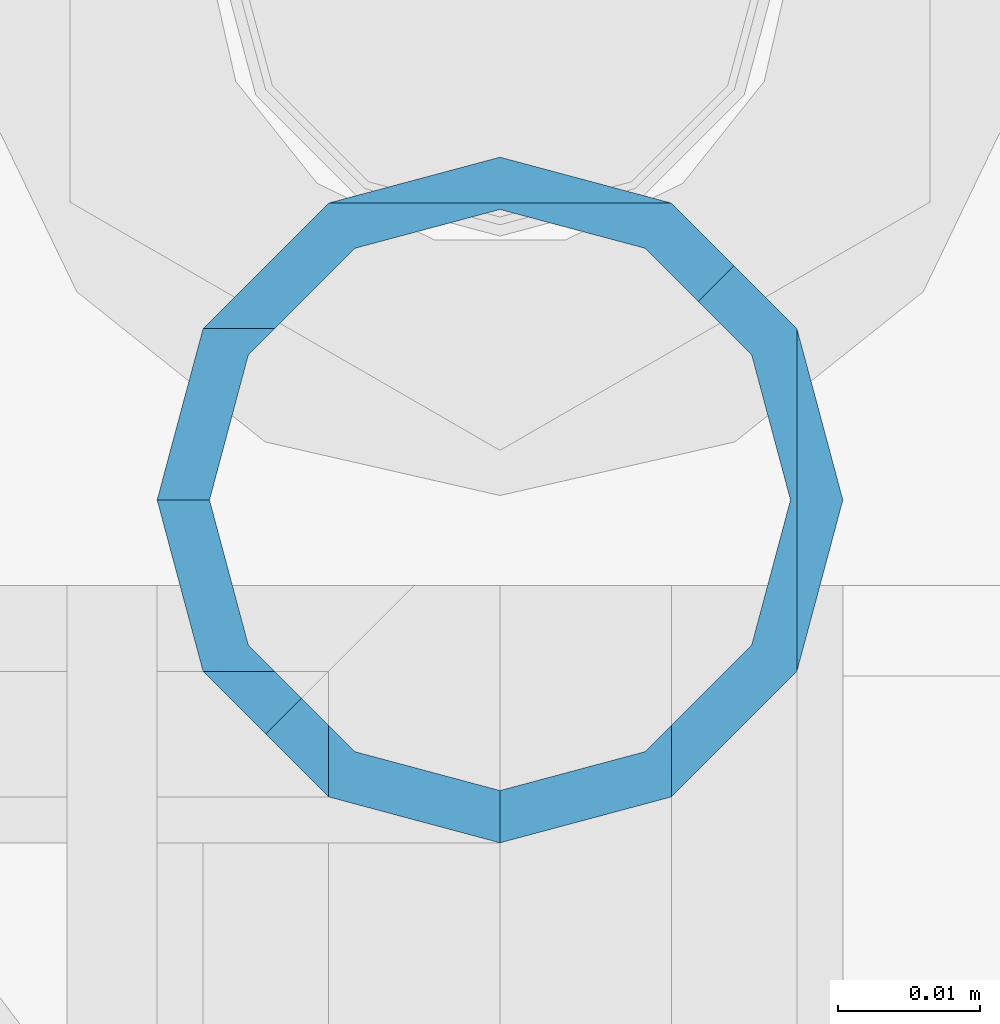
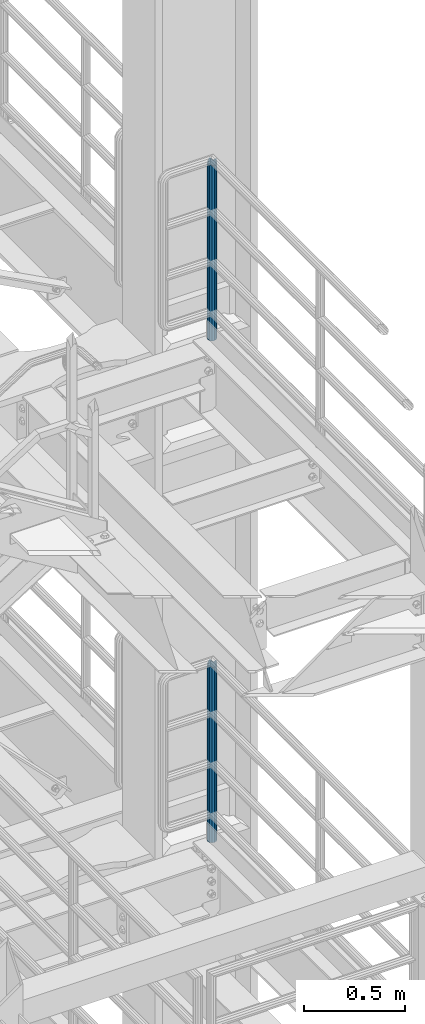
# One storey, part 665 of 1876: 2 columns, 2 elements without a shape of their own.
"""IFC2X3 building model written with IfcOpenShell, lengths in millimetres."""

from ifc_helpers import new_model, si_unit, frame, origin_with_axes, place, context, subcontext, project, spatial, faceted_brep, material, type_object, element, aggregate, save


model = new_model("IFC2X3")

# Units and contexts
model_context = context("Model", 3, precision=1e-05, world=origin_with_axes())
body_context = subcontext(model_context, "Body", "Model", "MODEL_VIEW")
ifc_project = project(units=[si_unit("LENGTHUNIT", "METRE", prefix="MILLI"), si_unit("AREAUNIT", "SQUARE_METRE"), si_unit("VOLUMEUNIT", "CUBIC_METRE"), si_unit("MASSUNIT", "GRAM", prefix="KILO"), si_unit("TIMEUNIT", "SECOND"), si_unit("PLANEANGLEUNIT", "RADIAN"), si_unit("SOLIDANGLEUNIT", "STERADIAN"), si_unit("THERMODYNAMICTEMPERATUREUNIT", "DEGREE_CELSIUS"), si_unit("LUMINOUSINTENSITYUNIT", "LUMEN")], contexts=[model_context])

# Site, building, storey
site_placement = place(None, origin_with_axes())
site = spatial("IfcSite", under=ifc_project, at=site_placement, CompositionType="ELEMENT")
building_placement = place(site_placement, origin_with_axes())
building = spatial("IfcBuilding", under=site, at=building_placement, Name="Undefined", CompositionType="ELEMENT")
storey_placement = place(building_placement, origin_with_axes())
storey = spatial("IfcBuildingStorey", under=building, at=storey_placement, Name="Undefined", CompositionType="ELEMENT", Elevation=0.0)

# Assembly, column
assembly_1_placement = place(storey_placement, origin_with_axes())
assembly_1 = element("IfcElementAssembly", 1, at=assembly_1_placement, inside=storey, Name="RAIL", AssemblyPlace="NOTDEFINED", PredefinedType="RIGID_FRAME")
ifc_material = material()
column_type = type_object("IfcColumnType", Name="PIPE1-1/2SCH40", PredefinedType="NOTDEFINED")
column_1_placement = place(assembly_1_placement, frame((7620.00000000001, -4788.2175, 8153.4), z_axis=(0.0, 1.0, 0.0), x_axis=(0.0, 0.0, 1.0)))
column_1 = element("IfcColumn", 2, at=column_1_placement, type_object=column_type, material=ifc_material, Name="POST", ObjectType="PIPE1-1/2SCH40", context=body_context, shape_type="Brep", body=[
    faceted_brep([(1076.325, 24.1300000000001, 0.0), (1064.26, 20.8971929933184, 12.0649999999996), (1064.25999999999, 20.8971929933186, -12.0649999999996), (1059.84389372958, 16.4810867391689, 16.4811062541503), (1057.32835795224, 13.9655509593422, 13.9655704718371), (1061.07042843786, 17.7076214311803, 10.2235000000001), (1063.80980700668, 20.4469999999999, 0.0), (1061.07042843786, 17.7076214311803, -10.2235000000001), (1055.42780700668, 12.0650000000001, -15.8661214311805), (1055.42780700667, 12.0649999999996, -20.8971929933186), (1054.93437856882, 10.2235000000001, -17.7076214311801), (1052.195, 0.0, -20.4470000000001), (1052.19499999999, 0.0, -24.1300000000001), (1055.42780700668, -12.0650000000001, -15.8661214311805), (1055.42780700667, -12.0649999999996, -20.8971929933186), (1054.93437856882, -10.2235000000001, -17.7076214311801), (1057.32837749231, -13.9655704718352, -13.9655509593449), (1059.84391327711, -16.4811062541476, -16.4810867391716), (1055.42780700668, -15.8661214311742, -12.065000000006), (1055.42780700668, -20.8971929933184, -12.0649999999996), (1054.93437856882, -17.7076214311801, -10.2235000000001), (1052.195, -20.4470000000001, 0.0), (1052.195, -24.1300000000001, 0.0), (1054.93437856882, -17.7076214311801, 10.2235000000001), (1055.42780700668, -15.8661214311869, 12.0649999999932), (1055.42780700668, -20.8971929933184, 12.0649999999996), (1076.325, 0.0, 24.1300000000001), (1064.26, -12.0650000000001, 20.8971929933186), (1064.26, 12.065, 20.8971929933186), (1061.07042843787, -10.2235000000001, 17.7076214311801), (1063.80980700669, 0.0, 20.4470000000001), (1061.07042843787, 10.2235000000001, 17.7076214311801), (0.0, -20.8971929933184, -12.0649999999996), (0.0, -12.0650000000001, -20.8971929933186), (-1.45519152283669e-11, 0.0, -24.130000000001), (0.0, 12.0650000000001, -20.8971929933186), (0.0, 20.8971929933184, -12.0649999999996), (0.0, 24.1299999999992, 0.0), (0.0, 20.8971929933184, 12.0649999999996), (0.0, 12.0650000000001, 20.8971929933186), (-1.45519152283669e-11, 0.0, 24.130000000001), (0.0, -20.8971929933184, 12.0649999999996), (0.0, -24.1299999999992, 0.0), (0.0, -12.0650000000001, 20.8971929933186), (0.0, -17.7076214311803, -10.2235000000001), (0.0, -10.2235000000001, -17.7076214311801), (-1.45519152283669e-11, 0.0, -20.4470000000001), (0.0, 10.2235000000001, -17.7076214311801), (0.0, 17.7076214311803, -10.2235000000001), (0.0, 20.4469999999999, 0.0), (0.0, 17.7076214311803, 10.2235000000001), (0.0, 10.2235000000001, 17.7076214311801), (-1.45519152283669e-11, 0.0, 20.4470000000001), (0.0, -10.2235000000001, 17.7076214311801), (0.0, -17.7076214311803, 10.2235000000001), (0.0, -20.4469999999999, 0.0)], [[[0, 1, 2]], [[3, 4, 5, 6, 7, 8, 9, 2, 1]], [[10, 11, 12, 9, 8]], [[13, 14, 12, 11, 15]], [[14, 13, 16, 17]], [[17, 16, 18, 19]], [[19, 18, 20, 21, 22]], [[22, 21, 23, 24, 25]], [[26, 27, 28]], [[25, 24, 29, 30, 31, 4, 3, 28, 27]], [[32, 33, 14, 17, 19]], [[33, 34, 12, 14]], [[34, 35, 9, 12]], [[35, 36, 2, 9]], [[36, 37, 0, 2]], [[37, 38, 1, 0]], [[1, 38, 39, 28, 3]], [[39, 40, 26, 28]], [[41, 42, 22, 25]], [[43, 41, 25, 27]], [[40, 43, 27, 26]], [[42, 32, 19, 22]], [[41, 43, 40, 39, 38, 37, 36, 35, 34, 33, 32, 42], [44, 45, 46, 47, 48, 49, 50, 51, 52, 53, 54, 55]], [[53, 52, 30, 29]], [[23, 54, 53, 29, 24]], [[55, 54, 23, 21]], [[44, 55, 21, 20]], [[15, 45, 44, 20, 18, 16, 13]], [[46, 45, 15, 11]], [[47, 46, 11, 10]], [[48, 47, 10, 8, 7]], [[49, 48, 7, 6]], [[50, 49, 6, 5]], [[51, 50, 5, 4, 31]], [[52, 51, 31, 30]]]),
])
aggregate(assembly_1, [column_1])

assembly_2_placement = place(storey_placement, origin_with_axes())
assembly_2 = element("IfcElementAssembly", 3, at=assembly_2_placement, inside=storey, Name="RAIL", AssemblyPlace="NOTDEFINED", PredefinedType="RIGID_FRAME")
column_2_placement = place(assembly_2_placement, frame((7620.00000000001, -4788.2175, 5130.8), z_axis=(0.0, 1.0, 0.0), x_axis=(0.0, 0.0, 1.0)))
column_2 = element("IfcColumn", 4, at=column_2_placement, type_object=column_type, material=ifc_material, Name="POST", ObjectType="PIPE1-1/2SCH40", context=body_context, shape_type="Brep", body=[
    faceted_brep([(1076.325, 24.1300000000001, 0.0), (1064.26, 20.8971929933184, 12.0649999999996), (1064.25999999999, 20.8971929933186, -12.0649999999996), (1059.84389372958, 16.4810867391689, 16.4811062541503), (1057.32835795224, 13.9655509593422, 13.9655704718371), (1061.07042843786, 17.7076214311803, 10.2235000000001), (1063.80980700668, 20.4469999999999, 0.0), (1061.07042843786, 17.7076214311803, -10.2235000000001), (1055.42780700668, 12.0650000000001, -15.8661214311805), (1055.42780700667, 12.0649999999996, -20.8971929933186), (1054.93437856882, 10.2235000000001, -17.7076214311801), (1052.195, 0.0, -20.4470000000001), (1052.19499999999, 0.0, -24.1300000000001), (1055.42780700668, -12.0650000000001, -15.8661214311805), (1055.42780700667, -12.0649999999996, -20.8971929933186), (1054.93437856882, -10.2235000000001, -17.7076214311801), (1057.32837749231, -13.9655704718352, -13.9655509593449), (1059.84391327711, -16.4811062541476, -16.4810867391716), (1055.42780700668, -15.8661214311742, -12.065000000006), (1055.42780700668, -20.8971929933184, -12.0649999999996), (1054.93437856882, -17.7076214311801, -10.2235000000001), (1052.195, -20.4470000000001, 0.0), (1052.195, -24.1300000000001, 0.0), (1054.93437856882, -17.7076214311801, 10.2235000000001), (1055.42780700668, -15.8661214311869, 12.0649999999932), (1055.42780700668, -20.8971929933184, 12.0649999999996), (1076.325, 0.0, 24.1300000000001), (1064.26, -12.0650000000001, 20.8971929933186), (1064.26, 12.065, 20.8971929933186), (1061.07042843787, -10.2235000000001, 17.7076214311801), (1063.80980700669, 0.0, 20.4470000000001), (1061.07042843787, 10.2235000000001, 17.7076214311801), (0.0, -20.8971929933184, -12.0649999999996), (0.0, -12.0650000000001, -20.8971929933186), (-1.45519152283669e-11, 0.0, -24.130000000001), (0.0, 12.0650000000001, -20.8971929933186), (0.0, 20.8971929933184, -12.0649999999996), (0.0, 24.1299999999992, 0.0), (0.0, 20.8971929933184, 12.0649999999996), (0.0, 12.0650000000001, 20.8971929933186), (-1.45519152283669e-11, 0.0, 24.130000000001), (0.0, -20.8971929933184, 12.0649999999996), (0.0, -24.1299999999992, 0.0), (0.0, -12.0650000000001, 20.8971929933186), (0.0, -17.7076214311803, -10.2235000000001), (0.0, -10.2235000000001, -17.7076214311801), (-1.45519152283669e-11, 0.0, -20.4470000000001), (0.0, 10.2235000000001, -17.7076214311801), (0.0, 17.7076214311803, -10.2235000000001), (0.0, 20.4469999999999, 0.0), (0.0, 17.7076214311803, 10.2235000000001), (0.0, 10.2235000000001, 17.7076214311801), (-1.45519152283669e-11, 0.0, 20.4470000000001), (0.0, -10.2235000000001, 17.7076214311801), (0.0, -17.7076214311803, 10.2235000000001), (0.0, -20.4469999999999, 0.0)], [[[0, 1, 2]], [[3, 4, 5, 6, 7, 8, 9, 2, 1]], [[10, 11, 12, 9, 8]], [[13, 14, 12, 11, 15]], [[14, 13, 16, 17]], [[17, 16, 18, 19]], [[19, 18, 20, 21, 22]], [[22, 21, 23, 24, 25]], [[26, 27, 28]], [[25, 24, 29, 30, 31, 4, 3, 28, 27]], [[32, 33, 14, 17, 19]], [[33, 34, 12, 14]], [[34, 35, 9, 12]], [[35, 36, 2, 9]], [[36, 37, 0, 2]], [[37, 38, 1, 0]], [[1, 38, 39, 28, 3]], [[39, 40, 26, 28]], [[41, 42, 22, 25]], [[43, 41, 25, 27]], [[40, 43, 27, 26]], [[42, 32, 19, 22]], [[41, 43, 40, 39, 38, 37, 36, 35, 34, 33, 32, 42], [44, 45, 46, 47, 48, 49, 50, 51, 52, 53, 54, 55]], [[53, 52, 30, 29]], [[23, 54, 53, 29, 24]], [[55, 54, 23, 21]], [[44, 55, 21, 20]], [[15, 45, 44, 20, 18, 16, 13]], [[46, 45, 15, 11]], [[47, 46, 11, 10]], [[48, 47, 10, 8, 7]], [[49, 48, 7, 6]], [[50, 49, 6, 5]], [[51, 50, 5, 4, 31]], [[52, 51, 31, 30]]]),
])
aggregate(assembly_2, [column_2])

save(model, "model.ifc")
